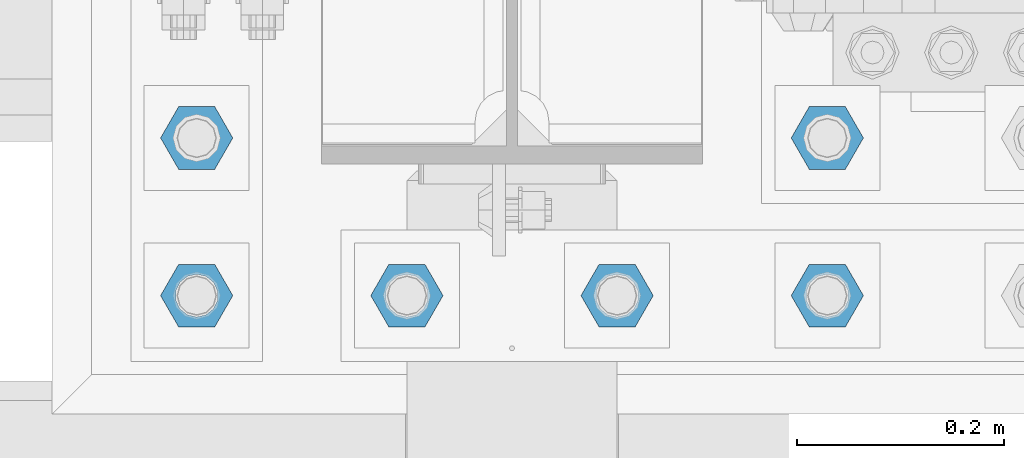
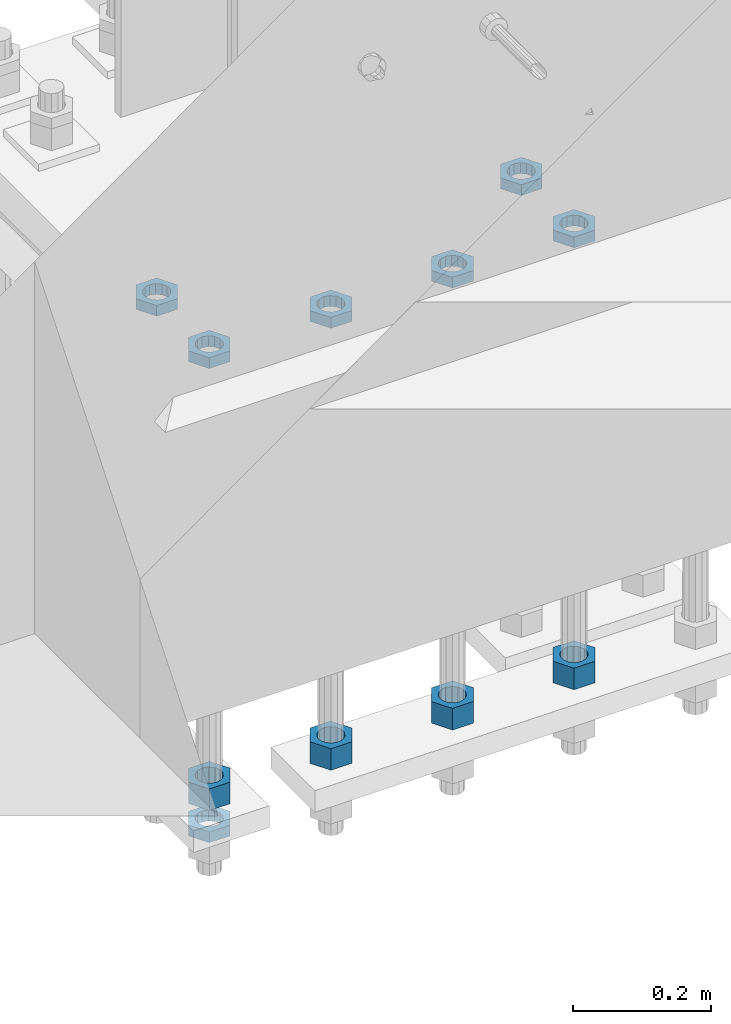
# One storey, part 2789 of 3843: 11 beams, 1 element without a shape of its own.
"""IFC2X3 building model written with IfcOpenShell, lengths in millimetres."""

from ifc_helpers import new_model, si_unit, frame, origin_with_axes, place, context, subcontext, project, spatial, faceted_brep, material, type_object, element, aggregate, save


model = new_model("IFC2X3")

# Units and contexts
model_context = context("Model", 3, precision=1e-05, world=origin_with_axes())
body_context = subcontext(model_context, "Body", "Model", "MODEL_VIEW")
ifc_project = project(units=[si_unit("LENGTHUNIT", "METRE", prefix="MILLI"), si_unit("AREAUNIT", "SQUARE_METRE"), si_unit("VOLUMEUNIT", "CUBIC_METRE"), si_unit("MASSUNIT", "GRAM", prefix="KILO"), si_unit("TIMEUNIT", "SECOND"), si_unit("PLANEANGLEUNIT", "RADIAN"), si_unit("SOLIDANGLEUNIT", "STERADIAN"), si_unit("THERMODYNAMICTEMPERATUREUNIT", "DEGREE_CELSIUS"), si_unit("LUMINOUSINTENSITYUNIT", "LUMEN")], contexts=[model_context])

# Site, building, storey
site_placement = place(None, origin_with_axes())
site = spatial("IfcSite", under=ifc_project, at=site_placement, CompositionType="ELEMENT")
building_placement = place(site_placement, origin_with_axes())
building = spatial("IfcBuilding", under=site, at=building_placement, Name="Undefined", CompositionType="ELEMENT")
storey_placement = place(building_placement, origin_with_axes())
storey = spatial("IfcBuildingStorey", under=building, at=storey_placement, Name="Undefined", CompositionType="ELEMENT", Elevation=0.0)

# Assembly, beams
assembly_placement = place(storey_placement, origin_with_axes())
assembly = element("IfcElementAssembly", 1, at=assembly_placement, inside=storey, Name="TEMPLATE", AssemblyPlace="NOTDEFINED", PredefinedType="RIGID_FRAME")
ifc_material = material(Name="STEEL/A572-50")
beam_type_1 = type_object("IfcBeamType", Name="1-1/2_HEAVY_HEX_NUT", PredefinedType="NOTDEFINED")
beam_1_placement = place(assembly_placement, frame((41757.6, 25311.1, 28841.7000015259), z_axis=(0.0, -1.0, 0.0), x_axis=(0.0, 0.0, -1.0)))
beam_1 = element("IfcBeam", 2, at=beam_1_placement, type_object=beam_type_1, material=ifc_material, Name="NUT", ObjectType="1-1/2_HEAVY_HEX_NUT", context=body_context, shape_type="Brep", body=[
    faceted_brep([(0.0, -34.9199981689453, 0.0), (0.0, -17.4599990844727, -30.25), (38.0999999999985, -17.4599990844727, -30.25), (38.0999999999985, -34.9199981689453, 0.0), (0.0, 17.4599990844727, -30.25), (38.0999999999985, 17.4599990844727, -30.25), (0.0, 34.9199981689453, 0.0), (38.0999999999985, 34.9199981689453, 0.0), (0.0, 17.4599990844727, 30.25), (38.0999999999985, 17.4599990844727, 30.25), (0.0, -17.4599990844727, 30.25), (38.0999999999985, -17.4599990844727, 30.25), (0.0, 0.0, 20.6399993896484), (0.0, 8.9553601105581, 18.5959968835959), (38.0999999999985, 8.9553601105581, 18.5959968835959), (38.0999999999985, 0.0, 20.6399993896484), (0.0, 16.1370013209525, 12.8688291298167), (38.0999999999985, 16.1370013209525, 12.8688291298167), (0.0, 20.1225115123816, 4.59283194104501), (38.0999999999985, 20.1225115123816, 4.59283194104501), (0.0, 20.1225115123816, -4.59283194104501), (38.0999999999985, 20.1225115123816, -4.59283194104501), (0.0, 16.1370013209525, -12.8688291298167), (38.0999999999985, 16.1370013209525, -12.8688291298167), (0.0, 8.9553601105581, -18.5959968835959), (38.0999999999985, 8.9553601105581, -18.5959968835959), (0.0, 0.0, -20.6399993896484), (38.0999999999985, 0.0, -20.6399993896484), (0.0, -8.9553601105581, -18.5959968835959), (38.0999999999985, -8.9553601105581, -18.5959968835959), (0.0, -16.1370013209525, -12.8688291298167), (38.0999999999985, -16.1370013209525, -12.8688291298167), (0.0, -20.1225115123816, -4.59283194104501), (38.0999999999985, -20.1225115123816, -4.59283194104501), (0.0, -20.1225115123816, 4.59283194104501), (38.0999999999985, -20.1225115123816, 4.59283194104501), (0.0, -16.1370013209525, 12.8688291298167), (38.0999999999985, -16.1370013209525, 12.8688291298167), (0.0, -8.9553601105581, 18.5959968835959), (38.0999999999985, -8.9553601105581, 18.5959968835959)], [[[0, 1, 2, 3]], [[1, 4, 5, 2]], [[4, 6, 7, 5]], [[6, 8, 9, 7]], [[8, 10, 11, 9]], [[10, 0, 3, 11]], [[12, 13, 14, 15]], [[13, 16, 17, 14]], [[16, 18, 19, 17]], [[18, 20, 21, 19]], [[20, 22, 23, 21]], [[22, 24, 25, 23]], [[24, 26, 27, 25]], [[26, 28, 29, 27]], [[28, 30, 31, 29]], [[30, 32, 33, 31]], [[32, 34, 35, 33]], [[34, 36, 37, 35]], [[36, 38, 39, 37]], [[38, 12, 15, 39]], [[5, 7, 9, 11, 3, 2], [17, 19, 21, 23, 25, 27, 29, 31, 33, 35, 37, 39, 15, 14]], [[10, 8, 6, 4, 1, 0], [38, 36, 34, 32, 30, 28, 26, 24, 22, 20, 18, 16, 13, 12]]]),
])
beam_2_placement = place(assembly_placement, frame((41960.8, 25311.1, 28841.7000015259), z_axis=(0.0, -1.0, 0.0), x_axis=(0.0, 0.0, -1.0)))
beam_2 = element("IfcBeam", 3, at=beam_2_placement, type_object=beam_type_1, material=ifc_material, Name="NUT", ObjectType="1-1/2_HEAVY_HEX_NUT", context=body_context, shape_type="Brep", body=[
    faceted_brep([(0.0, -34.9199981689453, 0.0), (0.0, -17.4599990844727, -30.25), (38.0999999999985, -17.4599990844727, -30.25), (38.0999999999985, -34.9199981689453, 0.0), (0.0, 17.4599990844727, -30.25), (38.0999999999985, 17.4599990844727, -30.25), (0.0, 34.9199981689453, 0.0), (38.0999999999985, 34.9199981689453, 0.0), (0.0, 17.4599990844727, 30.25), (38.0999999999985, 17.4599990844727, 30.25), (0.0, -17.4599990844727, 30.25), (38.0999999999985, -17.4599990844727, 30.25), (0.0, 0.0, 20.6399993896484), (0.0, 8.9553601105581, 18.5959968835959), (38.0999999999985, 8.9553601105581, 18.5959968835959), (38.0999999999985, 0.0, 20.6399993896484), (0.0, 16.1370013209525, 12.8688291298167), (38.0999999999985, 16.1370013209525, 12.8688291298167), (0.0, 20.1225115123816, 4.59283194104501), (38.0999999999985, 20.1225115123816, 4.59283194104501), (0.0, 20.1225115123816, -4.59283194104501), (38.0999999999985, 20.1225115123816, -4.59283194104501), (0.0, 16.1370013209525, -12.8688291298167), (38.0999999999985, 16.1370013209525, -12.8688291298167), (0.0, 8.9553601105581, -18.5959968835959), (38.0999999999985, 8.9553601105581, -18.5959968835959), (0.0, 0.0, -20.6399993896484), (38.0999999999985, 0.0, -20.6399993896484), (0.0, -8.9553601105581, -18.5959968835959), (38.0999999999985, -8.9553601105581, -18.5959968835959), (0.0, -16.1370013209525, -12.8688291298167), (38.0999999999985, -16.1370013209525, -12.8688291298167), (0.0, -20.1225115123816, -4.59283194104501), (38.0999999999985, -20.1225115123816, -4.59283194104501), (0.0, -20.1225115123816, 4.59283194104501), (38.0999999999985, -20.1225115123816, 4.59283194104501), (0.0, -16.1370013209525, 12.8688291298167), (38.0999999999985, -16.1370013209525, 12.8688291298167), (0.0, -8.9553601105581, 18.5959968835959), (38.0999999999985, -8.9553601105581, 18.5959968835959)], [[[0, 1, 2, 3]], [[1, 4, 5, 2]], [[4, 6, 7, 5]], [[6, 8, 9, 7]], [[8, 10, 11, 9]], [[10, 0, 3, 11]], [[12, 13, 14, 15]], [[13, 16, 17, 14]], [[16, 18, 19, 17]], [[18, 20, 21, 19]], [[20, 22, 23, 21]], [[22, 24, 25, 23]], [[24, 26, 27, 25]], [[26, 28, 29, 27]], [[28, 30, 31, 29]], [[30, 32, 33, 31]], [[32, 34, 35, 33]], [[34, 36, 37, 35]], [[36, 38, 39, 37]], [[38, 12, 15, 39]], [[5, 7, 9, 11, 3, 2], [17, 19, 21, 23, 25, 27, 29, 31, 33, 35, 37, 39, 15, 14]], [[10, 8, 6, 4, 1, 0], [38, 36, 34, 32, 30, 28, 26, 24, 22, 20, 18, 16, 13, 12]]]),
])
beam_3_placement = place(assembly_placement, frame((42164.0, 25311.1, 28841.7000015259), z_axis=(0.0, -1.0, 0.0), x_axis=(0.0, 0.0, -1.0)))
beam_3 = element("IfcBeam", 4, at=beam_3_placement, type_object=beam_type_1, material=ifc_material, Name="NUT", ObjectType="1-1/2_HEAVY_HEX_NUT", context=body_context, shape_type="Brep", body=[
    faceted_brep([(0.0, -34.9199981689453, 0.0), (0.0, -17.4599990844727, -30.25), (38.0999999999985, -17.4599990844727, -30.25), (38.0999999999985, -34.9199981689453, 0.0), (0.0, 17.4599990844727, -30.25), (38.0999999999985, 17.4599990844727, -30.25), (0.0, 34.9199981689453, 0.0), (38.0999999999985, 34.9199981689453, 0.0), (0.0, 17.4599990844727, 30.25), (38.0999999999985, 17.4599990844727, 30.25), (0.0, -17.4599990844727, 30.25), (38.0999999999985, -17.4599990844727, 30.25), (0.0, 0.0, 20.6399993896484), (0.0, 8.9553601105581, 18.5959968835959), (38.0999999999985, 8.9553601105581, 18.5959968835959), (38.0999999999985, 0.0, 20.6399993896484), (0.0, 16.1370013209525, 12.8688291298167), (38.0999999999985, 16.1370013209525, 12.8688291298167), (0.0, 20.1225115123816, 4.59283194104501), (38.0999999999985, 20.1225115123816, 4.59283194104501), (0.0, 20.1225115123816, -4.59283194104501), (38.0999999999985, 20.1225115123816, -4.59283194104501), (0.0, 16.1370013209525, -12.8688291298167), (38.0999999999985, 16.1370013209525, -12.8688291298167), (0.0, 8.9553601105581, -18.5959968835959), (38.0999999999985, 8.9553601105581, -18.5959968835959), (0.0, 0.0, -20.6399993896484), (38.0999999999985, 0.0, -20.6399993896484), (0.0, -8.9553601105581, -18.5959968835959), (38.0999999999985, -8.9553601105581, -18.5959968835959), (0.0, -16.1370013209525, -12.8688291298167), (38.0999999999985, -16.1370013209525, -12.8688291298167), (0.0, -20.1225115123816, -4.59283194104501), (38.0999999999985, -20.1225115123816, -4.59283194104501), (0.0, -20.1225115123816, 4.59283194104501), (38.0999999999985, -20.1225115123816, 4.59283194104501), (0.0, -16.1370013209525, 12.8688291298167), (38.0999999999985, -16.1370013209525, 12.8688291298167), (0.0, -8.9553601105581, 18.5959968835959), (38.0999999999985, -8.9553601105581, 18.5959968835959)], [[[0, 1, 2, 3]], [[1, 4, 5, 2]], [[4, 6, 7, 5]], [[6, 8, 9, 7]], [[8, 10, 11, 9]], [[10, 0, 3, 11]], [[12, 13, 14, 15]], [[13, 16, 17, 14]], [[16, 18, 19, 17]], [[18, 20, 21, 19]], [[20, 22, 23, 21]], [[22, 24, 25, 23]], [[24, 26, 27, 25]], [[26, 28, 29, 27]], [[28, 30, 31, 29]], [[30, 32, 33, 31]], [[32, 34, 35, 33]], [[34, 36, 37, 35]], [[36, 38, 39, 37]], [[38, 12, 15, 39]], [[5, 7, 9, 11, 3, 2], [17, 19, 21, 23, 25, 27, 29, 31, 33, 35, 37, 39, 15, 14]], [[10, 8, 6, 4, 1, 0], [38, 36, 34, 32, 30, 28, 26, 24, 22, 20, 18, 16, 13, 12]]]),
])
beam_4_placement = place(assembly_placement, frame((42367.2, 25311.1, 28841.7000015259), z_axis=(0.0, 1.0, 0.0), x_axis=(0.0, 0.0, -1.0)))
beam_4 = element("IfcBeam", 5, at=beam_4_placement, type_object=beam_type_1, material=ifc_material, Name="NUT", ObjectType="1-1/2_HEAVY_HEX_NUT", context=body_context, shape_type="Brep", body=[
    faceted_brep([(0.0, -34.9199981689453, 0.0), (0.0, -17.4599990844727, -30.25), (38.0999999999985, -17.4599990844727, -30.25), (38.0999999999985, -34.9199981689453, 0.0), (0.0, 17.4599990844727, -30.25), (38.0999999999985, 17.4599990844727, -30.25), (0.0, 34.9199981689453, 0.0), (38.0999999999985, 34.9199981689453, 0.0), (0.0, 17.4599990844727, 30.25), (38.0999999999985, 17.4599990844727, 30.25), (0.0, -17.4599990844727, 30.25), (38.0999999999985, -17.4599990844727, 30.25), (0.0, 0.0, 20.6399993896484), (0.0, 8.9553601105581, 18.5959968835959), (38.0999999999985, 8.9553601105581, 18.5959968835959), (38.0999999999985, 0.0, 20.6399993896484), (0.0, 16.1370013209525, 12.8688291298167), (38.0999999999985, 16.1370013209525, 12.8688291298167), (0.0, 20.1225115123816, 4.59283194104501), (38.0999999999985, 20.1225115123816, 4.59283194104501), (0.0, 20.1225115123816, -4.59283194104501), (38.0999999999985, 20.1225115123816, -4.59283194104501), (0.0, 16.1370013209525, -12.8688291298167), (38.0999999999985, 16.1370013209525, -12.8688291298167), (0.0, 8.9553601105581, -18.5959968835959), (38.0999999999985, 8.9553601105581, -18.5959968835959), (0.0, 0.0, -20.6399993896484), (38.0999999999985, 0.0, -20.6399993896484), (0.0, -8.9553601105581, -18.5959968835959), (38.0999999999985, -8.9553601105581, -18.5959968835959), (0.0, -16.1370013209525, -12.8688291298167), (38.0999999999985, -16.1370013209525, -12.8688291298167), (0.0, -20.1225115123816, -4.59283194104501), (38.0999999999985, -20.1225115123816, -4.59283194104501), (0.0, -20.1225115123816, 4.59283194104501), (38.0999999999985, -20.1225115123816, 4.59283194104501), (0.0, -16.1370013209525, 12.8688291298167), (38.0999999999985, -16.1370013209525, 12.8688291298167), (0.0, -8.9553601105581, 18.5959968835959), (38.0999999999985, -8.9553601105581, 18.5959968835959)], [[[0, 1, 2, 3]], [[1, 4, 5, 2]], [[4, 6, 7, 5]], [[6, 8, 9, 7]], [[8, 10, 11, 9]], [[10, 0, 3, 11]], [[12, 13, 14, 15]], [[13, 16, 17, 14]], [[16, 18, 19, 17]], [[18, 20, 21, 19]], [[20, 22, 23, 21]], [[22, 24, 25, 23]], [[24, 26, 27, 25]], [[26, 28, 29, 27]], [[28, 30, 31, 29]], [[30, 32, 33, 31]], [[32, 34, 35, 33]], [[34, 36, 37, 35]], [[36, 38, 39, 37]], [[38, 12, 15, 39]], [[5, 7, 9, 11, 3, 2], [17, 19, 21, 23, 25, 27, 29, 31, 33, 35, 37, 39, 15, 14]], [[10, 8, 6, 4, 1, 0], [38, 36, 34, 32, 30, 28, 26, 24, 22, 20, 18, 16, 13, 12]]]),
])
beam_type_2 = type_object("IfcBeamType", Name="1-1/2_HALF_NUT", PredefinedType="NOTDEFINED")
beam_5_placement = place(assembly_placement, frame((42367.2, 25463.5, 29603.7), z_axis=(0.0, 1.0, 0.0), x_axis=(0.0, 0.0, -1.0)))
beam_5 = element("IfcBeam", 6, at=beam_5_placement, type_object=beam_type_2, material=ifc_material, Name="NUT", ObjectType="1-1/2_HALF_NUT", context=body_context, shape_type="Brep", body=[
    faceted_brep([(0.0, -34.9199981689453, 0.0), (0.0, -17.4599990844727, -30.25), (19.0500000000029, -17.4599990844727, -30.25), (19.0500000000029, -34.9199981689453, 0.0), (0.0, 17.4599990844727, -30.25), (19.0500000000029, 17.4599990844727, -30.25), (0.0, 34.9199981689453, 0.0), (19.0500000000029, 34.9199981689453, 0.0), (0.0, 17.4599990844727, 30.25), (19.0500000000029, 17.4599990844727, 30.25), (0.0, -17.4599990844727, 30.25), (19.0500000000029, -17.4599990844727, 30.25), (0.0, 0.0, 20.6399993896484), (0.0, 8.9553601105581, 18.5959968835959), (19.0500000000029, 8.95536011056538, 18.5959968835959), (19.0500000000029, 0.0, 20.6399993896484), (0.0, 16.1370013209525, 12.8688291298167), (19.0500000000029, 16.1370013209489, 12.8688291298167), (0.0, 20.1225115123816, 4.59283194104501), (19.0500000000029, 20.1225115123852, 4.59283194104501), (0.0, 20.1225115123816, -4.59283194104501), (19.0500000000029, 20.1225115123852, -4.59283194104501), (0.0, 16.1370013209525, -12.8688291298167), (19.0500000000029, 16.1370013209489, -12.8688291298167), (0.0, 8.9553601105581, -18.5959968835959), (19.0500000000029, 8.95536011056538, -18.5959968835959), (0.0, 0.0, -20.6399993896484), (19.0500000000029, 0.0, -20.6399993896484), (0.0, -8.9553601105581, -18.5959968835959), (19.0500000000029, -8.95536011056538, -18.5959968835959), (0.0, -16.1370013209525, -12.8688291298167), (19.0500000000029, -16.1370013209489, -12.8688291298167), (0.0, -20.1225115123816, -4.59283194104501), (19.0500000000029, -20.1225115123852, -4.59283194104501), (0.0, -20.1225115123816, 4.59283194104501), (19.0500000000029, -20.1225115123852, 4.59283194104501), (0.0, -16.1370013209525, 12.8688291298167), (19.0500000000029, -16.1370013209489, 12.8688291298167), (0.0, -8.9553601105581, 18.5959968835959), (19.0500000000029, -8.95536011056538, 18.5959968835959)], [[[0, 1, 2, 3]], [[1, 4, 5, 2]], [[4, 6, 7, 5]], [[6, 8, 9, 7]], [[8, 10, 11, 9]], [[10, 0, 3, 11]], [[12, 13, 14, 15]], [[13, 16, 17, 14]], [[16, 18, 19, 17]], [[18, 20, 21, 19]], [[20, 22, 23, 21]], [[22, 24, 25, 23]], [[24, 26, 27, 25]], [[26, 28, 29, 27]], [[28, 30, 31, 29]], [[30, 32, 33, 31]], [[32, 34, 35, 33]], [[34, 36, 37, 35]], [[36, 38, 39, 37]], [[38, 12, 15, 39]], [[5, 7, 9, 11, 3, 2], [17, 19, 21, 23, 25, 27, 29, 31, 33, 35, 37, 39, 15, 14]], [[10, 8, 6, 4, 1, 0], [38, 36, 34, 32, 30, 28, 26, 24, 22, 20, 18, 16, 13, 12]]]),
])
beam_6_placement = place(assembly_placement, frame((42367.2, 25311.1, 29603.7), z_axis=(0.0, 1.0, 0.0), x_axis=(0.0, 0.0, -1.0)))
beam_6 = element("IfcBeam", 7, at=beam_6_placement, type_object=beam_type_2, material=ifc_material, Name="NUT", ObjectType="1-1/2_HALF_NUT", context=body_context, shape_type="Brep", body=[
    faceted_brep([(0.0, -34.9199981689453, 0.0), (0.0, -17.4599990844727, -30.25), (19.0500000000029, -17.4599990844727, -30.25), (19.0500000000029, -34.9199981689453, 0.0), (0.0, 17.4599990844727, -30.25), (19.0500000000029, 17.4599990844727, -30.25), (0.0, 34.9199981689453, 0.0), (19.0500000000029, 34.9199981689453, 0.0), (0.0, 17.4599990844727, 30.25), (19.0500000000029, 17.4599990844727, 30.25), (0.0, -17.4599990844727, 30.25), (19.0500000000029, -17.4599990844727, 30.25), (0.0, 0.0, 20.6399993896484), (0.0, 8.9553601105581, 18.5959968835959), (19.0500000000029, 8.95536011056538, 18.5959968835959), (19.0500000000029, 0.0, 20.6399993896484), (0.0, 16.1370013209525, 12.8688291298167), (19.0500000000029, 16.1370013209489, 12.8688291298167), (0.0, 20.1225115123816, 4.59283194104501), (19.0500000000029, 20.1225115123852, 4.59283194104501), (0.0, 20.1225115123816, -4.59283194104501), (19.0500000000029, 20.1225115123852, -4.59283194104501), (0.0, 16.1370013209525, -12.8688291298167), (19.0500000000029, 16.1370013209489, -12.8688291298167), (0.0, 8.9553601105581, -18.5959968835959), (19.0500000000029, 8.95536011056538, -18.5959968835959), (0.0, 0.0, -20.6399993896484), (19.0500000000029, 0.0, -20.6399993896484), (0.0, -8.9553601105581, -18.5959968835959), (19.0500000000029, -8.95536011056538, -18.5959968835959), (0.0, -16.1370013209525, -12.8688291298167), (19.0500000000029, -16.1370013209489, -12.8688291298167), (0.0, -20.1225115123816, -4.59283194104501), (19.0500000000029, -20.1225115123852, -4.59283194104501), (0.0, -20.1225115123816, 4.59283194104501), (19.0500000000029, -20.1225115123852, 4.59283194104501), (0.0, -16.1370013209525, 12.8688291298167), (19.0500000000029, -16.1370013209489, 12.8688291298167), (0.0, -8.9553601105581, 18.5959968835959), (19.0500000000029, -8.95536011056538, 18.5959968835959)], [[[0, 1, 2, 3]], [[1, 4, 5, 2]], [[4, 6, 7, 5]], [[6, 8, 9, 7]], [[8, 10, 11, 9]], [[10, 0, 3, 11]], [[12, 13, 14, 15]], [[13, 16, 17, 14]], [[16, 18, 19, 17]], [[18, 20, 21, 19]], [[20, 22, 23, 21]], [[22, 24, 25, 23]], [[24, 26, 27, 25]], [[26, 28, 29, 27]], [[28, 30, 31, 29]], [[30, 32, 33, 31]], [[32, 34, 35, 33]], [[34, 36, 37, 35]], [[36, 38, 39, 37]], [[38, 12, 15, 39]], [[5, 7, 9, 11, 3, 2], [17, 19, 21, 23, 25, 27, 29, 31, 33, 35, 37, 39, 15, 14]], [[10, 8, 6, 4, 1, 0], [38, 36, 34, 32, 30, 28, 26, 24, 22, 20, 18, 16, 13, 12]]]),
])
beam_7_placement = place(assembly_placement, frame((42164.0, 25311.1, 29603.7), z_axis=(0.0, -1.0, 0.0), x_axis=(0.0, 0.0, -1.0)))
beam_7 = element("IfcBeam", 8, at=beam_7_placement, type_object=beam_type_2, material=ifc_material, Name="NUT", ObjectType="1-1/2_HALF_NUT", context=body_context, shape_type="Brep", body=[
    faceted_brep([(0.0, -34.9199981689453, 0.0), (0.0, -17.4599990844727, -30.25), (19.0500000000029, -17.4599990844727, -30.25), (19.0500000000029, -34.9199981689453, 0.0), (0.0, 17.4599990844727, -30.25), (19.0500000000029, 17.4599990844727, -30.25), (0.0, 34.9199981689453, 0.0), (19.0500000000029, 34.9199981689453, 0.0), (0.0, 17.4599990844727, 30.25), (19.0500000000029, 17.4599990844727, 30.25), (0.0, -17.4599990844727, 30.25), (19.0500000000029, -17.4599990844727, 30.25), (0.0, 0.0, 20.6399993896484), (0.0, 8.9553601105581, 18.5959968835959), (19.0500000000029, 8.95536011056538, 18.5959968835959), (19.0500000000029, 0.0, 20.6399993896484), (0.0, 16.1370013209525, 12.8688291298167), (19.0500000000029, 16.1370013209489, 12.8688291298167), (0.0, 20.1225115123816, 4.59283194104501), (19.0500000000029, 20.1225115123852, 4.59283194104501), (0.0, 20.1225115123816, -4.59283194104501), (19.0500000000029, 20.1225115123852, -4.59283194104501), (0.0, 16.1370013209525, -12.8688291298167), (19.0500000000029, 16.1370013209489, -12.8688291298167), (0.0, 8.9553601105581, -18.5959968835959), (19.0500000000029, 8.95536011056538, -18.5959968835959), (0.0, 0.0, -20.6399993896484), (19.0500000000029, 0.0, -20.6399993896484), (0.0, -8.9553601105581, -18.5959968835959), (19.0500000000029, -8.95536011056538, -18.5959968835959), (0.0, -16.1370013209525, -12.8688291298167), (19.0500000000029, -16.1370013209489, -12.8688291298167), (0.0, -20.1225115123816, -4.59283194104501), (19.0500000000029, -20.1225115123852, -4.59283194104501), (0.0, -20.1225115123816, 4.59283194104501), (19.0500000000029, -20.1225115123852, 4.59283194104501), (0.0, -16.1370013209525, 12.8688291298167), (19.0500000000029, -16.1370013209489, 12.8688291298167), (0.0, -8.9553601105581, 18.5959968835959), (19.0500000000029, -8.95536011056538, 18.5959968835959)], [[[0, 1, 2, 3]], [[1, 4, 5, 2]], [[4, 6, 7, 5]], [[6, 8, 9, 7]], [[8, 10, 11, 9]], [[10, 0, 3, 11]], [[12, 13, 14, 15]], [[13, 16, 17, 14]], [[16, 18, 19, 17]], [[18, 20, 21, 19]], [[20, 22, 23, 21]], [[22, 24, 25, 23]], [[24, 26, 27, 25]], [[26, 28, 29, 27]], [[28, 30, 31, 29]], [[30, 32, 33, 31]], [[32, 34, 35, 33]], [[34, 36, 37, 35]], [[36, 38, 39, 37]], [[38, 12, 15, 39]], [[5, 7, 9, 11, 3, 2], [17, 19, 21, 23, 25, 27, 29, 31, 33, 35, 37, 39, 15, 14]], [[10, 8, 6, 4, 1, 0], [38, 36, 34, 32, 30, 28, 26, 24, 22, 20, 18, 16, 13, 12]]]),
])
beam_8_placement = place(assembly_placement, frame((41960.8, 25311.1, 29603.7), z_axis=(0.0, -1.0, 0.0), x_axis=(0.0, 0.0, -1.0)))
beam_8 = element("IfcBeam", 9, at=beam_8_placement, type_object=beam_type_2, material=ifc_material, Name="NUT", ObjectType="1-1/2_HALF_NUT", context=body_context, shape_type="Brep", body=[
    faceted_brep([(0.0, -34.9199981689453, 0.0), (0.0, -17.4599990844727, -30.25), (19.0500000000029, -17.4599990844727, -30.25), (19.0500000000029, -34.9199981689453, 0.0), (0.0, 17.4599990844727, -30.25), (19.0500000000029, 17.4599990844727, -30.25), (0.0, 34.9199981689453, 0.0), (19.0500000000029, 34.9199981689453, 0.0), (0.0, 17.4599990844727, 30.25), (19.0500000000029, 17.4599990844727, 30.25), (0.0, -17.4599990844727, 30.25), (19.0500000000029, -17.4599990844727, 30.25), (0.0, 0.0, 20.6399993896484), (0.0, 8.9553601105581, 18.5959968835959), (19.0500000000029, 8.95536011056538, 18.5959968835959), (19.0500000000029, 0.0, 20.6399993896484), (0.0, 16.1370013209525, 12.8688291298167), (19.0500000000029, 16.1370013209489, 12.8688291298167), (0.0, 20.1225115123816, 4.59283194104501), (19.0500000000029, 20.1225115123852, 4.59283194104501), (0.0, 20.1225115123816, -4.59283194104501), (19.0500000000029, 20.1225115123852, -4.59283194104501), (0.0, 16.1370013209525, -12.8688291298167), (19.0500000000029, 16.1370013209489, -12.8688291298167), (0.0, 8.9553601105581, -18.5959968835959), (19.0500000000029, 8.95536011056538, -18.5959968835959), (0.0, 0.0, -20.6399993896484), (19.0500000000029, 0.0, -20.6399993896484), (0.0, -8.9553601105581, -18.5959968835959), (19.0500000000029, -8.95536011056538, -18.5959968835959), (0.0, -16.1370013209525, -12.8688291298167), (19.0500000000029, -16.1370013209489, -12.8688291298167), (0.0, -20.1225115123816, -4.59283194104501), (19.0500000000029, -20.1225115123852, -4.59283194104501), (0.0, -20.1225115123816, 4.59283194104501), (19.0500000000029, -20.1225115123852, 4.59283194104501), (0.0, -16.1370013209525, 12.8688291298167), (19.0500000000029, -16.1370013209489, 12.8688291298167), (0.0, -8.9553601105581, 18.5959968835959), (19.0500000000029, -8.95536011056538, 18.5959968835959)], [[[0, 1, 2, 3]], [[1, 4, 5, 2]], [[4, 6, 7, 5]], [[6, 8, 9, 7]], [[8, 10, 11, 9]], [[10, 0, 3, 11]], [[12, 13, 14, 15]], [[13, 16, 17, 14]], [[16, 18, 19, 17]], [[18, 20, 21, 19]], [[20, 22, 23, 21]], [[22, 24, 25, 23]], [[24, 26, 27, 25]], [[26, 28, 29, 27]], [[28, 30, 31, 29]], [[30, 32, 33, 31]], [[32, 34, 35, 33]], [[34, 36, 37, 35]], [[36, 38, 39, 37]], [[38, 12, 15, 39]], [[5, 7, 9, 11, 3, 2], [17, 19, 21, 23, 25, 27, 29, 31, 33, 35, 37, 39, 15, 14]], [[10, 8, 6, 4, 1, 0], [38, 36, 34, 32, 30, 28, 26, 24, 22, 20, 18, 16, 13, 12]]]),
])
beam_9_placement = place(assembly_placement, frame((41757.6, 25463.5, 29603.7), z_axis=(0.0, -1.0, 0.0), x_axis=(0.0, 0.0, -1.0)))
beam_9 = element("IfcBeam", 10, at=beam_9_placement, type_object=beam_type_2, material=ifc_material, Name="NUT", ObjectType="1-1/2_HALF_NUT", context=body_context, shape_type="Brep", body=[
    faceted_brep([(0.0, -34.9199981689453, 0.0), (0.0, -17.4599990844727, -30.25), (19.0500000000029, -17.4599990844727, -30.25), (19.0500000000029, -34.9199981689453, 0.0), (0.0, 17.4599990844727, -30.25), (19.0500000000029, 17.4599990844727, -30.25), (0.0, 34.9199981689453, 0.0), (19.0500000000029, 34.9199981689453, 0.0), (0.0, 17.4599990844727, 30.25), (19.0500000000029, 17.4599990844727, 30.25), (0.0, -17.4599990844727, 30.25), (19.0500000000029, -17.4599990844727, 30.25), (0.0, 0.0, 20.6399993896484), (0.0, 8.9553601105581, 18.5959968835959), (19.0500000000029, 8.95536011056538, 18.5959968835959), (19.0500000000029, 0.0, 20.6399993896484), (0.0, 16.1370013209525, 12.8688291298167), (19.0500000000029, 16.1370013209489, 12.8688291298167), (0.0, 20.1225115123816, 4.59283194104501), (19.0500000000029, 20.1225115123852, 4.59283194104501), (0.0, 20.1225115123816, -4.59283194104501), (19.0500000000029, 20.1225115123852, -4.59283194104501), (0.0, 16.1370013209525, -12.8688291298167), (19.0500000000029, 16.1370013209489, -12.8688291298167), (0.0, 8.9553601105581, -18.5959968835959), (19.0500000000029, 8.95536011056538, -18.5959968835959), (0.0, 0.0, -20.6399993896484), (19.0500000000029, 0.0, -20.6399993896484), (0.0, -8.9553601105581, -18.5959968835959), (19.0500000000029, -8.95536011056538, -18.5959968835959), (0.0, -16.1370013209525, -12.8688291298167), (19.0500000000029, -16.1370013209489, -12.8688291298167), (0.0, -20.1225115123816, -4.59283194104501), (19.0500000000029, -20.1225115123852, -4.59283194104501), (0.0, -20.1225115123816, 4.59283194104501), (19.0500000000029, -20.1225115123852, 4.59283194104501), (0.0, -16.1370013209525, 12.8688291298167), (19.0500000000029, -16.1370013209489, 12.8688291298167), (0.0, -8.9553601105581, 18.5959968835959), (19.0500000000029, -8.95536011056538, 18.5959968835959)], [[[0, 1, 2, 3]], [[1, 4, 5, 2]], [[4, 6, 7, 5]], [[6, 8, 9, 7]], [[8, 10, 11, 9]], [[10, 0, 3, 11]], [[12, 13, 14, 15]], [[13, 16, 17, 14]], [[16, 18, 19, 17]], [[18, 20, 21, 19]], [[20, 22, 23, 21]], [[22, 24, 25, 23]], [[24, 26, 27, 25]], [[26, 28, 29, 27]], [[28, 30, 31, 29]], [[30, 32, 33, 31]], [[32, 34, 35, 33]], [[34, 36, 37, 35]], [[36, 38, 39, 37]], [[38, 12, 15, 39]], [[5, 7, 9, 11, 3, 2], [17, 19, 21, 23, 25, 27, 29, 31, 33, 35, 37, 39, 15, 14]], [[10, 8, 6, 4, 1, 0], [38, 36, 34, 32, 30, 28, 26, 24, 22, 20, 18, 16, 13, 12]]]),
])
beam_10_placement = place(assembly_placement, frame((41757.6, 25311.1, 29603.7), z_axis=(0.0, -1.0, 0.0), x_axis=(0.0, 0.0, -1.0)))
beam_10 = element("IfcBeam", 11, at=beam_10_placement, type_object=beam_type_2, material=ifc_material, Name="NUT", ObjectType="1-1/2_HALF_NUT", context=body_context, shape_type="Brep", body=[
    faceted_brep([(0.0, -34.9199981689453, 0.0), (0.0, -17.4599990844727, -30.25), (19.0500000000029, -17.4599990844727, -30.25), (19.0500000000029, -34.9199981689453, 0.0), (0.0, 17.4599990844727, -30.25), (19.0500000000029, 17.4599990844727, -30.25), (0.0, 34.9199981689453, 0.0), (19.0500000000029, 34.9199981689453, 0.0), (0.0, 17.4599990844727, 30.25), (19.0500000000029, 17.4599990844727, 30.25), (0.0, -17.4599990844727, 30.25), (19.0500000000029, -17.4599990844727, 30.25), (0.0, 0.0, 20.6399993896484), (0.0, 8.9553601105581, 18.5959968835959), (19.0500000000029, 8.95536011056538, 18.5959968835959), (19.0500000000029, 0.0, 20.6399993896484), (0.0, 16.1370013209525, 12.8688291298167), (19.0500000000029, 16.1370013209489, 12.8688291298167), (0.0, 20.1225115123816, 4.59283194104501), (19.0500000000029, 20.1225115123852, 4.59283194104501), (0.0, 20.1225115123816, -4.59283194104501), (19.0500000000029, 20.1225115123852, -4.59283194104501), (0.0, 16.1370013209525, -12.8688291298167), (19.0500000000029, 16.1370013209489, -12.8688291298167), (0.0, 8.9553601105581, -18.5959968835959), (19.0500000000029, 8.95536011056538, -18.5959968835959), (0.0, 0.0, -20.6399993896484), (19.0500000000029, 0.0, -20.6399993896484), (0.0, -8.9553601105581, -18.5959968835959), (19.0500000000029, -8.95536011056538, -18.5959968835959), (0.0, -16.1370013209525, -12.8688291298167), (19.0500000000029, -16.1370013209489, -12.8688291298167), (0.0, -20.1225115123816, -4.59283194104501), (19.0500000000029, -20.1225115123852, -4.59283194104501), (0.0, -20.1225115123816, 4.59283194104501), (19.0500000000029, -20.1225115123852, 4.59283194104501), (0.0, -16.1370013209525, 12.8688291298167), (19.0500000000029, -16.1370013209489, 12.8688291298167), (0.0, -8.9553601105581, 18.5959968835959), (19.0500000000029, -8.95536011056538, 18.5959968835959)], [[[0, 1, 2, 3]], [[1, 4, 5, 2]], [[4, 6, 7, 5]], [[6, 8, 9, 7]], [[8, 10, 11, 9]], [[10, 0, 3, 11]], [[12, 13, 14, 15]], [[13, 16, 17, 14]], [[16, 18, 19, 17]], [[18, 20, 21, 19]], [[20, 22, 23, 21]], [[22, 24, 25, 23]], [[24, 26, 27, 25]], [[26, 28, 29, 27]], [[28, 30, 31, 29]], [[30, 32, 33, 31]], [[32, 34, 35, 33]], [[34, 36, 37, 35]], [[36, 38, 39, 37]], [[38, 12, 15, 39]], [[5, 7, 9, 11, 3, 2], [17, 19, 21, 23, 25, 27, 29, 31, 33, 35, 37, 39, 15, 14]], [[10, 8, 6, 4, 1, 0], [38, 36, 34, 32, 30, 28, 26, 24, 22, 20, 18, 16, 13, 12]]]),
])
beam_11_placement = place(assembly_placement, frame((41757.6, 25311.1, 28765.5000015259), z_axis=(0.0, -1.0, 0.0), x_axis=(0.0, 0.0, -1.0)))
beam_11 = element("IfcBeam", 12, at=beam_11_placement, type_object=beam_type_2, material=ifc_material, Name="NUT", ObjectType="1-1/2_HALF_NUT", context=body_context, shape_type="Brep", body=[
    faceted_brep([(0.0, -34.9199981689453, 0.0), (0.0, -17.4599990844727, -30.25), (19.0500000000029, -17.4599990844727, -30.25), (19.0500000000029, -34.9199981689453, 0.0), (0.0, 17.4599990844727, -30.25), (19.0500000000029, 17.4599990844727, -30.25), (0.0, 34.9199981689453, 0.0), (19.0500000000029, 34.9199981689453, 0.0), (0.0, 17.4599990844727, 30.25), (19.0500000000029, 17.4599990844727, 30.25), (0.0, -17.4599990844727, 30.25), (19.0500000000029, -17.4599990844727, 30.25), (0.0, 0.0, 20.6399993896484), (0.0, 8.9553601105581, 18.5959968835959), (19.0500000000029, 8.95536011056538, 18.5959968835959), (19.0500000000029, 0.0, 20.6399993896484), (0.0, 16.1370013209525, 12.8688291298167), (19.0500000000029, 16.1370013209489, 12.8688291298167), (0.0, 20.1225115123816, 4.59283194104501), (19.0500000000029, 20.1225115123852, 4.59283194104501), (0.0, 20.1225115123816, -4.59283194104501), (19.0500000000029, 20.1225115123852, -4.59283194104501), (0.0, 16.1370013209525, -12.8688291298167), (19.0500000000029, 16.1370013209489, -12.8688291298167), (0.0, 8.9553601105581, -18.5959968835959), (19.0500000000029, 8.95536011056538, -18.5959968835959), (0.0, 0.0, -20.6399993896484), (19.0500000000029, 0.0, -20.6399993896484), (0.0, -8.9553601105581, -18.5959968835959), (19.0500000000029, -8.95536011056538, -18.5959968835959), (0.0, -16.1370013209525, -12.8688291298167), (19.0500000000029, -16.1370013209489, -12.8688291298167), (0.0, -20.1225115123816, -4.59283194104501), (19.0500000000029, -20.1225115123852, -4.59283194104501), (0.0, -20.1225115123816, 4.59283194104501), (19.0500000000029, -20.1225115123852, 4.59283194104501), (0.0, -16.1370013209525, 12.8688291298167), (19.0500000000029, -16.1370013209489, 12.8688291298167), (0.0, -8.9553601105581, 18.5959968835959), (19.0500000000029, -8.95536011056538, 18.5959968835959)], [[[0, 1, 2, 3]], [[1, 4, 5, 2]], [[4, 6, 7, 5]], [[6, 8, 9, 7]], [[8, 10, 11, 9]], [[10, 0, 3, 11]], [[12, 13, 14, 15]], [[13, 16, 17, 14]], [[16, 18, 19, 17]], [[18, 20, 21, 19]], [[20, 22, 23, 21]], [[22, 24, 25, 23]], [[24, 26, 27, 25]], [[26, 28, 29, 27]], [[28, 30, 31, 29]], [[30, 32, 33, 31]], [[32, 34, 35, 33]], [[34, 36, 37, 35]], [[36, 38, 39, 37]], [[38, 12, 15, 39]], [[5, 7, 9, 11, 3, 2], [17, 19, 21, 23, 25, 27, 29, 31, 33, 35, 37, 39, 15, 14]], [[10, 8, 6, 4, 1, 0], [38, 36, 34, 32, 30, 28, 26, 24, 22, 20, 18, 16, 13, 12]]]),
])
aggregate(assembly, [beam_1, beam_2, beam_3, beam_4, beam_5, beam_6, beam_7, beam_8, beam_9, beam_10, beam_11])

save(model, "model.ifc")
